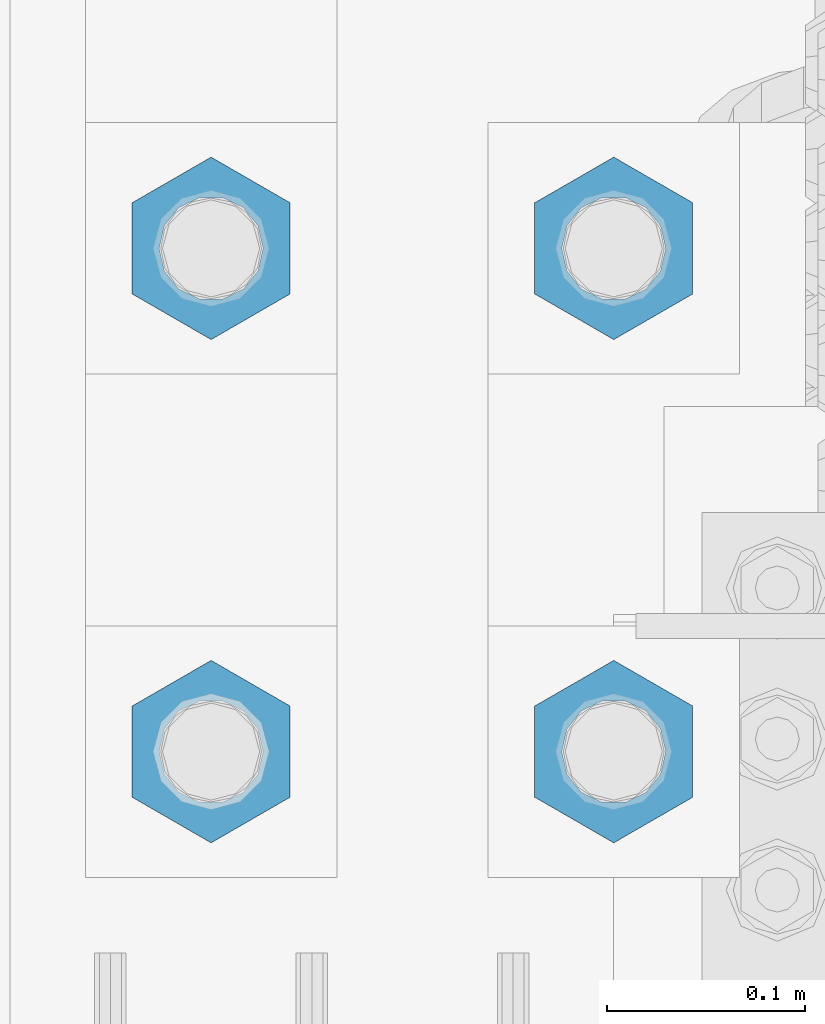
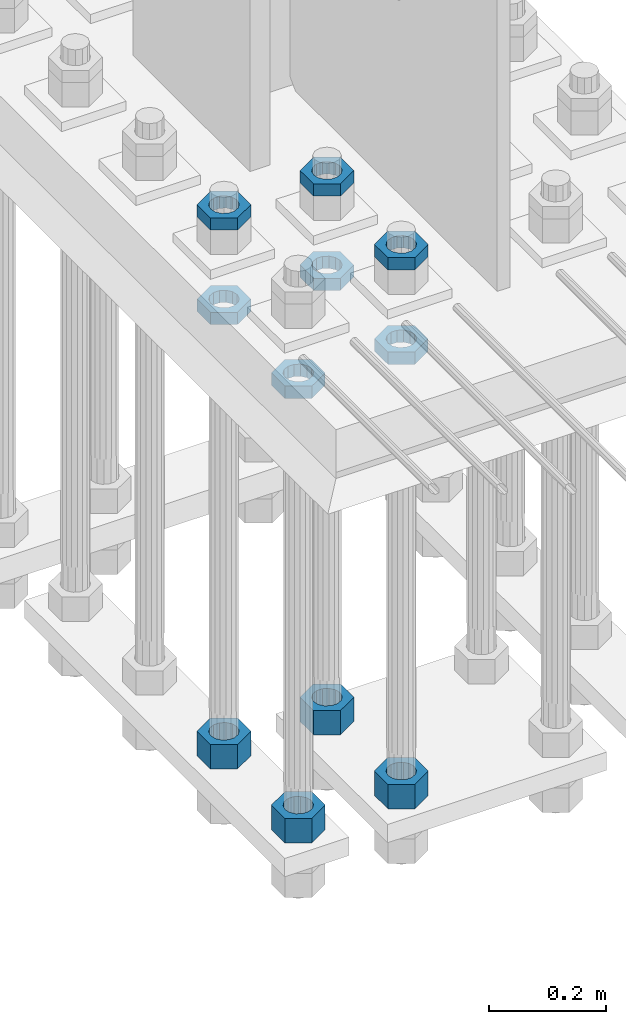
# One storey, part 2210 of 3843: 11 beams, 1 element without a shape of its own.
"""IFC2X3 building model written with IfcOpenShell, lengths in millimetres."""

import ifcopenshell
import ifcopenshell.guid

model = None  # the IFC model being written
_history = None  # IfcOwnerHistory: only IFC2X3 demands one
_inside = {}  # id of a spatial element -> (the spatial element, [elements in it])
_under = {}  # id of a project, library or spatial element -> (it, [spatial elements below it])
_declared = {}  # id of a project -> (the project, [libraries it declares])
_typed = {}  # id of a type object -> (the type object, [elements of that type])
_made_of = {}  # id of a material, layer set ... -> (it, [elements and type objects made of it])


def new_model(schema):
    """Start an empty IFC model of exactly this schema.

    Asked for "IFC4X3", IfcOpenShell would pick the latest addendum, in which some entities
    have other attributes; the version numbers below select the first issue.
    IFC2X3 requires an IfcOwnerHistory on every rooted entity: one is made here for all.
    """
    global model, _history
    if schema == "IFC4X3":
        model = ifcopenshell.file(schema_version=(4, 3, 0, 0))
    else:
        model = ifcopenshell.file(schema=schema)
    _inside.clear()
    _under.clear()
    _declared.clear()
    _typed.clear()
    _made_of.clear()
    _history = None
    if model.schema == "IFC2X3":
        org = make("IfcOrganization", Name="unknown")
        user = make(
            "IfcPersonAndOrganization",
            ThePerson=make("IfcPerson", FamilyName="unknown"),
            TheOrganization=org,
        )
        app = make(
            "IfcApplication",
            ApplicationDeveloper=org,
            Version="unknown",
            ApplicationFullName="unknown",
            ApplicationIdentifier="unknown",
        )
        _history = make(
            "IfcOwnerHistory",
            OwningUser=user,
            OwningApplication=app,
            ChangeAction="ADDED",
            CreationDate=0,
        )
    return model


def make(cls, **values):
    """One entity of the class cls with the attributes given. An attribute that is None is left unset."""
    return model.create_entity(
        cls, **{name: value for name, value in values.items() if value is not None}
    )


def rooted(cls, **values):
    """An entity with a GlobalId (a new one), such as an element, a storey or a relation."""
    return make(cls, GlobalId=ifcopenshell.guid.new(), OwnerHistory=_history, **values)


def si_unit(unit_type, name, prefix=None):
    """IfcSIUnit, for example si_unit("LENGTHUNIT", "METRE", prefix="MILLI")."""
    return make("IfcSIUnit", UnitType=unit_type, Prefix=prefix, Name=name)


def assignment(units):
    """IfcUnitAssignment: the units of a project."""
    return None if units is None else make("IfcUnitAssignment", Units=units)


def point(xyz):
    """IfcCartesianPoint."""
    return None if xyz is None else make("IfcCartesianPoint", Coordinates=xyz)


def direction(xyz):
    """IfcDirection."""
    return None if xyz is None else make("IfcDirection", DirectionRatios=xyz)


def frame(location, z_axis=None, x_axis=None):
    """IfcAxis2Placement3D, a coordinate frame: its origin and axes. An axis left out is left unset."""
    return make(
        "IfcAxis2Placement3D",
        Location=point(location),
        Axis=direction(z_axis),
        RefDirection=direction(x_axis),
    )


def origin_with_axes():
    """The frame at (0, 0, 0) with the z axis (0, 0, 1) and the x axis (1, 0, 0) written out."""
    return frame((0.0, 0.0, 0.0), z_axis=(0.0, 0.0, 1.0), x_axis=(1.0, 0.0, 0.0))


def place(relative_to, where):
    """IfcLocalPlacement: puts the frame where relative to a parent placement (None: the world)."""
    return make(
        "IfcLocalPlacement", PlacementRelTo=relative_to, RelativePlacement=where
    )


def context(
    kind, dimensions, precision=None, world=None, true_north=None, identifier=None
):
    """IfcGeometricRepresentationContext, for example the 3D "Model" context."""
    return make(
        "IfcGeometricRepresentationContext",
        ContextIdentifier=identifier,
        ContextType=kind,
        CoordinateSpaceDimension=dimensions,
        Precision=precision,
        WorldCoordinateSystem=world,
        TrueNorth=true_north,
    )


def subcontext(parent, identifier, kind, view, scale=None):
    """IfcGeometricRepresentationSubContext, for example "Body" below "Model"."""
    return make(
        "IfcGeometricRepresentationSubContext",
        ContextIdentifier=identifier,
        ContextType=kind,
        ParentContext=parent,
        TargetScale=scale,
        TargetView=view,
    )


def project(units=None, contexts=None):
    """IfcProject with its units and contexts."""
    return rooted(
        "IfcProject",
        Name="project",
        RepresentationContexts=contexts,
        UnitsInContext=assignment(units),
    )


def spatial(cls, under=None, at=None, **own):
    """A site, building, storey or space (cls), placed at a placement, below another one or the project."""
    s = rooted(cls, ObjectPlacement=at, **own)
    if under is not None:
        _under.setdefault(under.id(), (under, []))[1].append(s)
    return s


def faces_of(points, faces, orient=None, outer=None):
    """IfcFace entities. A face is a list of loops; a loop is a list of indices into points, from 0.

    orient and outer hold one flag for each loop. By default every Orientation is true, the
    first loop of a face is its IfcFaceOuterBound and the others are IfcFaceBound.
    """
    made = []
    for i, loops in enumerate(faces):
        bounds = []
        for j, loop in enumerate(loops):
            is_outer = j == 0 if outer is None else outer[i][j]
            bounds.append(
                make(
                    "IfcFaceOuterBound" if is_outer else "IfcFaceBound",
                    Bound=make("IfcPolyLoop", Polygon=[points[k] for k in loop]),
                    Orientation=True if orient is None else orient[i][j],
                )
            )
        made.append(make("IfcFace", Bounds=bounds))
    return made


def faceted_brep(points, faces, orient=None, outer=None, voids=None):
    """IfcFacetedBrep: a solid bounded by flat faces; with voids (closed shells), ...WithVoids."""
    shared = [point(p) for p in points]
    hull = make("IfcClosedShell", CfsFaces=faces_of(shared, faces, orient, outer))
    if voids is None:
        return make("IfcFacetedBrep", Outer=hull)
    return make(
        "IfcFacetedBrepWithVoids",
        Outer=hull,
        Voids=[
            make(cls, CfsFaces=faces_of(shared, fs, o, b)) for cls, fs, o, b in voids
        ],
    )


def shape(context_of_items, identifier, shape_type, items):
    """IfcShapeRepresentation: the items that make up one representation, for example the "Body"."""
    return make(
        "IfcShapeRepresentation",
        ContextOfItems=context_of_items,
        RepresentationIdentifier=identifier,
        RepresentationType=shape_type,
        Items=items,
    )


def material(Name=None, Category=None):
    """IfcMaterial."""
    return make("IfcMaterial", Name=Name, Category=Category)


def made_of(thing, what):
    """Note that an element or type object is made of a material, layer set ...; save() writes the relation."""
    if what is not None:
        _made_of.setdefault(what.id(), (what, []))[1].append(thing)
    return thing


def type_object(cls, material=None, **own):
    """A type object (cls), such as IfcWallType, which elements share."""
    return made_of(rooted(cls, **own), material)


def element(
    cls,
    number,
    at=None,
    inside=None,
    cuts=None,
    type_object=None,
    material=None,
    context=None,
    identifier="Body",
    shape_type=None,
    held_by="IfcProductDefinitionShape",
    body=None,
    shapes=None,
    **own,
):
    """One element of the class cls, such as IfcWall. Its Tag is "e" and its number.

    at: its placement. inside: the storey or other place that contains it. cuts: it is an
    opening in that element (IfcRelVoidsElement). A single representation is given by context,
    identifier, shape_type and body (its items); several are given by shapes. held_by: the class
    of the entity that holds the representations. save() writes the other relations.
    """
    e = rooted(cls, Tag="e%d" % number, ObjectPlacement=at, **own)
    if body is not None:
        shapes = [shape(context, identifier, shape_type, body)]
    if shapes is not None:
        e.Representation = make(held_by, Representations=shapes)
    if inside is not None:
        _inside.setdefault(inside.id(), (inside, []))[1].append(e)
    if cuts is not None:
        rooted(
            "IfcRelVoidsElement", RelatingBuildingElement=cuts, RelatedOpeningElement=e
        )
    if type_object is not None:
        _typed.setdefault(type_object.id(), (type_object, []))[1].append(e)
    return made_of(e, material)


def aggregate(whole, parts):
    """IfcRelAggregates: a whole, such as a stair, and the parts it consists of."""
    return rooted("IfcRelAggregates", RelatingObject=whole, RelatedObjects=parts)


def save(model, path):
    """Write the relations noted so far, then the file.

    IfcRelAggregates (storeys below a building ...), IfcRelContainedInSpatialStructure (elements
    in a storey), IfcRelDefinesByType, IfcRelAssociatesMaterial and IfcRelDeclares: one each for
    every whole, place, type object, material and project.
    """
    for whole, parts in _under.values():
        aggregate(whole, parts)
    for where, things in _inside.values():
        rooted(
            "IfcRelContainedInSpatialStructure",
            RelatedElements=things,
            RelatingStructure=where,
        )
    for kind, things in _typed.values():
        rooted("IfcRelDefinesByType", RelatedObjects=things, RelatingType=kind)
    for what, things in _made_of.values():
        rooted("IfcRelAssociatesMaterial", RelatedObjects=things, RelatingMaterial=what)
    for by, libraries in _declared.values():
        rooted("IfcRelDeclares", RelatingContext=by, RelatedDefinitions=libraries)
    model.write(path)


model = new_model("IFC2X3")

# Units and contexts
model_context = context("Model", 3, precision=1e-05, world=origin_with_axes())
body_context = subcontext(model_context, "Body", "Model", "MODEL_VIEW")
ifc_project = project(units=[si_unit("LENGTHUNIT", "METRE", prefix="MILLI"), si_unit("AREAUNIT", "SQUARE_METRE"), si_unit("VOLUMEUNIT", "CUBIC_METRE"), si_unit("MASSUNIT", "GRAM", prefix="KILO"), si_unit("TIMEUNIT", "SECOND"), si_unit("PLANEANGLEUNIT", "RADIAN"), si_unit("SOLIDANGLEUNIT", "STERADIAN"), si_unit("THERMODYNAMICTEMPERATUREUNIT", "DEGREE_CELSIUS"), si_unit("LUMINOUSINTENSITYUNIT", "LUMEN")], contexts=[model_context])

# Site, building, storey
site_placement = place(None, origin_with_axes())
site = spatial("IfcSite", under=ifc_project, at=site_placement, CompositionType="ELEMENT")
building_placement = place(site_placement, origin_with_axes())
building = spatial("IfcBuilding", under=site, at=building_placement, Name="Undefined", CompositionType="ELEMENT")
storey_placement = place(building_placement, origin_with_axes())
storey = spatial("IfcBuildingStorey", under=building, at=storey_placement, Name="Undefined", CompositionType="ELEMENT", Elevation=0.0)

# Assembly, beams
assembly_placement = place(storey_placement, origin_with_axes())
assembly = element("IfcElementAssembly", 1, at=assembly_placement, inside=storey, Name="TEMPLATE", AssemblyPlace="NOTDEFINED", PredefinedType="RIGID_FRAME")
ifc_material = material(Name="STEEL/A572-50")
beam_type_1 = type_object("IfcBeamType", Name="2_HALF_NUT", PredefinedType="NOTDEFINED")
beam_1_placement = place(assembly_placement, frame((36220.4, 58280.3, 30060.9), z_axis=(-1.0, 0.0, 0.0), x_axis=(0.0, 0.0, -1.0)))
beam_1 = element("IfcBeam", 2, at=beam_1_placement, type_object=beam_type_1, material=ifc_material, Name="NUT", ObjectType="2_HALF_NUT", context=body_context, shape_type="Brep", body=[
    faceted_brep([(0.0, -46.0369987487793, 0.0), (0.0, -23.0184993743896, -39.869213104248), (25.4000000000015, -23.0184993743896, -39.869213104248), (25.4000000000015, -46.0369987487793, 0.0), (0.0, 23.0184993743896, -39.869213104248), (25.4000000000015, 23.0184993743896, -39.869213104248), (0.0, 46.0369987487793, 0.0), (25.4000000000015, 46.0369987487793, 0.0), (0.0, 23.0184993743896, 39.869213104248), (25.4000000000015, 23.0184993743896, 39.869213104248), (0.0, -23.0184993743896, 39.869213104248), (25.4000000000015, -23.0184993743896, 39.869213104248), (0.0, 0.0, 26.1940002441406), (0.0, 11.3650617044477, 23.5999013092805), (25.4000000000015, 11.3650617044477, 23.5999013092805), (25.4000000000015, 0.0, 26.1940002441406), (0.0, 20.4791109456419, 16.3316083006721), (25.4000000000015, 20.4791109456419, 16.3316083006721), (0.0, 25.5370200498292, 5.82867859874386), (25.4000000000015, 25.5370200498292, 5.82867859874386), (0.0, 25.5370200498292, -5.82867859874386), (25.4000000000015, 25.5370200498292, -5.82867859874386), (0.0, 20.4791109456419, -16.3316083006721), (25.4000000000015, 20.4791109456419, -16.3316083006721), (0.0, 11.3650617044477, -23.5999013092805), (25.4000000000015, 11.3650617044477, -23.5999013092805), (0.0, 0.0, -26.1940002441406), (25.4000000000015, 0.0, -26.1940002441406), (0.0, -11.3650617044477, -23.5999013092805), (25.4000000000015, -11.3650617044477, -23.5999013092805), (0.0, -20.4791109456419, -16.3316083006721), (25.4000000000015, -20.4791109456419, -16.3316083006721), (0.0, -25.5370200498292, -5.82867859874386), (25.4000000000015, -25.5370200498292, -5.82867859874386), (0.0, -25.5370200498292, 5.82867859874386), (25.4000000000015, -25.5370200498292, 5.82867859874386), (0.0, -20.4791109456419, 16.3316083006721), (25.4000000000015, -20.4791109456419, 16.3316083006721), (0.0, -11.3650617044477, 23.5999013092805), (25.4000000000015, -11.3650617044477, 23.5999013092805)], [[[0, 1, 2, 3]], [[1, 4, 5, 2]], [[4, 6, 7, 5]], [[6, 8, 9, 7]], [[8, 10, 11, 9]], [[10, 0, 3, 11]], [[12, 13, 14, 15]], [[13, 16, 17, 14]], [[16, 18, 19, 17]], [[18, 20, 21, 19]], [[20, 22, 23, 21]], [[22, 24, 25, 23]], [[24, 26, 27, 25]], [[26, 28, 29, 27]], [[28, 30, 31, 29]], [[30, 32, 33, 31]], [[32, 34, 35, 33]], [[34, 36, 37, 35]], [[36, 38, 39, 37]], [[38, 12, 15, 39]], [[5, 7, 9, 11, 3, 2], [17, 19, 21, 23, 25, 27, 29, 31, 33, 35, 37, 39, 15, 14]], [[10, 8, 6, 4, 1, 0], [38, 36, 34, 32, 30, 28, 26, 24, 22, 20, 18, 16, 13, 12]]]),
])
beam_2_placement = place(assembly_placement, frame((36423.6, 58280.3, 30060.9), z_axis=(-1.0, 0.0, 0.0), x_axis=(0.0, 0.0, -1.0)))
beam_2 = element("IfcBeam", 3, at=beam_2_placement, type_object=beam_type_1, material=ifc_material, Name="NUT", ObjectType="2_HALF_NUT", context=body_context, shape_type="Brep", body=[
    faceted_brep([(0.0, -46.0369987487793, 0.0), (0.0, -23.0184993743896, -39.869213104248), (25.4000000000015, -23.0184993743896, -39.869213104248), (25.4000000000015, -46.0369987487793, 0.0), (0.0, 23.0184993743896, -39.869213104248), (25.4000000000015, 23.0184993743896, -39.869213104248), (0.0, 46.0369987487793, 0.0), (25.4000000000015, 46.0369987487793, 0.0), (0.0, 23.0184993743896, 39.869213104248), (25.4000000000015, 23.0184993743896, 39.869213104248), (0.0, -23.0184993743896, 39.869213104248), (25.4000000000015, -23.0184993743896, 39.869213104248), (0.0, 0.0, 26.1940002441406), (0.0, 11.3650617044477, 23.5999013092805), (25.4000000000015, 11.3650617044477, 23.5999013092805), (25.4000000000015, 0.0, 26.1940002441406), (0.0, 20.4791109456419, 16.3316083006721), (25.4000000000015, 20.4791109456419, 16.3316083006721), (0.0, 25.5370200498292, 5.82867859874386), (25.4000000000015, 25.5370200498292, 5.82867859874386), (0.0, 25.5370200498292, -5.82867859874386), (25.4000000000015, 25.5370200498292, -5.82867859874386), (0.0, 20.4791109456419, -16.3316083006721), (25.4000000000015, 20.4791109456419, -16.3316083006721), (0.0, 11.3650617044477, -23.5999013092805), (25.4000000000015, 11.3650617044477, -23.5999013092805), (0.0, 0.0, -26.1940002441406), (25.4000000000015, 0.0, -26.1940002441406), (0.0, -11.3650617044477, -23.5999013092805), (25.4000000000015, -11.3650617044477, -23.5999013092805), (0.0, -20.4791109456419, -16.3316083006721), (25.4000000000015, -20.4791109456419, -16.3316083006721), (0.0, -25.5370200498292, -5.82867859874386), (25.4000000000015, -25.5370200498292, -5.82867859874386), (0.0, -25.5370200498292, 5.82867859874386), (25.4000000000015, -25.5370200498292, 5.82867859874386), (0.0, -20.4791109456419, 16.3316083006721), (25.4000000000015, -20.4791109456419, 16.3316083006721), (0.0, -11.3650617044477, 23.5999013092805), (25.4000000000015, -11.3650617044477, 23.5999013092805)], [[[0, 1, 2, 3]], [[1, 4, 5, 2]], [[4, 6, 7, 5]], [[6, 8, 9, 7]], [[8, 10, 11, 9]], [[10, 0, 3, 11]], [[12, 13, 14, 15]], [[13, 16, 17, 14]], [[16, 18, 19, 17]], [[18, 20, 21, 19]], [[20, 22, 23, 21]], [[22, 24, 25, 23]], [[24, 26, 27, 25]], [[26, 28, 29, 27]], [[28, 30, 31, 29]], [[30, 32, 33, 31]], [[32, 34, 35, 33]], [[34, 36, 37, 35]], [[36, 38, 39, 37]], [[38, 12, 15, 39]], [[5, 7, 9, 11, 3, 2], [17, 19, 21, 23, 25, 27, 29, 31, 33, 35, 37, 39, 15, 14]], [[10, 8, 6, 4, 1, 0], [38, 36, 34, 32, 30, 28, 26, 24, 22, 20, 18, 16, 13, 12]]]),
])
beam_3_placement = place(assembly_placement, frame((36423.6, 58534.3, 30060.9), z_axis=(-1.0, 0.0, 0.0), x_axis=(0.0, 0.0, -1.0)))
beam_3 = element("IfcBeam", 4, at=beam_3_placement, type_object=beam_type_1, material=ifc_material, Name="NUT", ObjectType="2_HALF_NUT", context=body_context, shape_type="Brep", body=[
    faceted_brep([(0.0, -46.0369987487793, 0.0), (0.0, -23.0184993743896, -39.869213104248), (25.4000000000015, -23.0184993743896, -39.869213104248), (25.4000000000015, -46.0369987487793, 0.0), (0.0, 23.0184993743896, -39.869213104248), (25.4000000000015, 23.0184993743896, -39.869213104248), (0.0, 46.0369987487793, 0.0), (25.4000000000015, 46.0369987487793, 0.0), (0.0, 23.0184993743896, 39.869213104248), (25.4000000000015, 23.0184993743896, 39.869213104248), (0.0, -23.0184993743896, 39.869213104248), (25.4000000000015, -23.0184993743896, 39.869213104248), (0.0, 0.0, 26.1940002441406), (0.0, 11.3650617044477, 23.5999013092805), (25.4000000000015, 11.3650617044477, 23.5999013092805), (25.4000000000015, 0.0, 26.1940002441406), (0.0, 20.4791109456419, 16.3316083006721), (25.4000000000015, 20.4791109456419, 16.3316083006721), (0.0, 25.5370200498292, 5.82867859874386), (25.4000000000015, 25.5370200498292, 5.82867859874386), (0.0, 25.5370200498292, -5.82867859874386), (25.4000000000015, 25.5370200498292, -5.82867859874386), (0.0, 20.4791109456419, -16.3316083006721), (25.4000000000015, 20.4791109456419, -16.3316083006721), (0.0, 11.3650617044477, -23.5999013092805), (25.4000000000015, 11.3650617044477, -23.5999013092805), (0.0, 0.0, -26.1940002441406), (25.4000000000015, 0.0, -26.1940002441406), (0.0, -11.3650617044477, -23.5999013092805), (25.4000000000015, -11.3650617044477, -23.5999013092805), (0.0, -20.4791109456419, -16.3316083006721), (25.4000000000015, -20.4791109456419, -16.3316083006721), (0.0, -25.5370200498292, -5.82867859874386), (25.4000000000015, -25.5370200498292, -5.82867859874386), (0.0, -25.5370200498292, 5.82867859874386), (25.4000000000015, -25.5370200498292, 5.82867859874386), (0.0, -20.4791109456419, 16.3316083006721), (25.4000000000015, -20.4791109456419, 16.3316083006721), (0.0, -11.3650617044477, 23.5999013092805), (25.4000000000015, -11.3650617044477, 23.5999013092805)], [[[0, 1, 2, 3]], [[1, 4, 5, 2]], [[4, 6, 7, 5]], [[6, 8, 9, 7]], [[8, 10, 11, 9]], [[10, 0, 3, 11]], [[12, 13, 14, 15]], [[13, 16, 17, 14]], [[16, 18, 19, 17]], [[18, 20, 21, 19]], [[20, 22, 23, 21]], [[22, 24, 25, 23]], [[24, 26, 27, 25]], [[26, 28, 29, 27]], [[28, 30, 31, 29]], [[30, 32, 33, 31]], [[32, 34, 35, 33]], [[34, 36, 37, 35]], [[36, 38, 39, 37]], [[38, 12, 15, 39]], [[5, 7, 9, 11, 3, 2], [17, 19, 21, 23, 25, 27, 29, 31, 33, 35, 37, 39, 15, 14]], [[10, 8, 6, 4, 1, 0], [38, 36, 34, 32, 30, 28, 26, 24, 22, 20, 18, 16, 13, 12]]]),
])
beam_4_placement = place(assembly_placement, frame((36220.4, 58534.3, 30060.9), z_axis=(-1.0, 0.0, 0.0), x_axis=(0.0, 0.0, -1.0)))
beam_4 = element("IfcBeam", 5, at=beam_4_placement, type_object=beam_type_1, material=ifc_material, Name="NUT", ObjectType="2_HALF_NUT", context=body_context, shape_type="Brep", body=[
    faceted_brep([(0.0, -46.0369987487793, 0.0), (0.0, -23.0184993743896, -39.869213104248), (25.4000000000015, -23.0184993743896, -39.869213104248), (25.4000000000015, -46.0369987487793, 0.0), (0.0, 23.0184993743896, -39.869213104248), (25.4000000000015, 23.0184993743896, -39.869213104248), (0.0, 46.0369987487793, 0.0), (25.4000000000015, 46.0369987487793, 0.0), (0.0, 23.0184993743896, 39.869213104248), (25.4000000000015, 23.0184993743896, 39.869213104248), (0.0, -23.0184993743896, 39.869213104248), (25.4000000000015, -23.0184993743896, 39.869213104248), (0.0, 0.0, 26.1940002441406), (0.0, 11.3650617044477, 23.5999013092805), (25.4000000000015, 11.3650617044477, 23.5999013092805), (25.4000000000015, 0.0, 26.1940002441406), (0.0, 20.4791109456419, 16.3316083006721), (25.4000000000015, 20.4791109456419, 16.3316083006721), (0.0, 25.5370200498292, 5.82867859874386), (25.4000000000015, 25.5370200498292, 5.82867859874386), (0.0, 25.5370200498292, -5.82867859874386), (25.4000000000015, 25.5370200498292, -5.82867859874386), (0.0, 20.4791109456419, -16.3316083006721), (25.4000000000015, 20.4791109456419, -16.3316083006721), (0.0, 11.3650617044477, -23.5999013092805), (25.4000000000015, 11.3650617044477, -23.5999013092805), (0.0, 0.0, -26.1940002441406), (25.4000000000015, 0.0, -26.1940002441406), (0.0, -11.3650617044477, -23.5999013092805), (25.4000000000015, -11.3650617044477, -23.5999013092805), (0.0, -20.4791109456419, -16.3316083006721), (25.4000000000015, -20.4791109456419, -16.3316083006721), (0.0, -25.5370200498292, -5.82867859874386), (25.4000000000015, -25.5370200498292, -5.82867859874386), (0.0, -25.5370200498292, 5.82867859874386), (25.4000000000015, -25.5370200498292, 5.82867859874386), (0.0, -20.4791109456419, 16.3316083006721), (25.4000000000015, -20.4791109456419, 16.3316083006721), (0.0, -11.3650617044477, 23.5999013092805), (25.4000000000015, -11.3650617044477, 23.5999013092805)], [[[0, 1, 2, 3]], [[1, 4, 5, 2]], [[4, 6, 7, 5]], [[6, 8, 9, 7]], [[8, 10, 11, 9]], [[10, 0, 3, 11]], [[12, 13, 14, 15]], [[13, 16, 17, 14]], [[16, 18, 19, 17]], [[18, 20, 21, 19]], [[20, 22, 23, 21]], [[22, 24, 25, 23]], [[24, 26, 27, 25]], [[26, 28, 29, 27]], [[28, 30, 31, 29]], [[30, 32, 33, 31]], [[32, 34, 35, 33]], [[34, 36, 37, 35]], [[36, 38, 39, 37]], [[38, 12, 15, 39]], [[5, 7, 9, 11, 3, 2], [17, 19, 21, 23, 25, 27, 29, 31, 33, 35, 37, 39, 15, 14]], [[10, 8, 6, 4, 1, 0], [38, 36, 34, 32, 30, 28, 26, 24, 22, 20, 18, 16, 13, 12]]]),
])
beam_5_placement = place(assembly_placement, frame((36423.6, 58280.3, 30257.75), z_axis=(-1.0, 0.0, 0.0), x_axis=(0.0, 0.0, -1.0)))
beam_5 = element("IfcBeam", 6, at=beam_5_placement, type_object=beam_type_1, material=ifc_material, Name="NUT", ObjectType="2_HALF_NUT", context=body_context, shape_type="Brep", body=[
    faceted_brep([(0.0, -46.0369987487793, 0.0), (0.0, -23.0184993743896, -39.869213104248), (25.4000000000015, -23.0184993743896, -39.869213104248), (25.4000000000015, -46.0369987487793, 0.0), (0.0, 23.0184993743896, -39.869213104248), (25.4000000000015, 23.0184993743896, -39.869213104248), (0.0, 46.0369987487793, 0.0), (25.4000000000015, 46.0369987487793, 0.0), (0.0, 23.0184993743896, 39.869213104248), (25.4000000000015, 23.0184993743896, 39.869213104248), (0.0, -23.0184993743896, 39.869213104248), (25.4000000000015, -23.0184993743896, 39.869213104248), (0.0, 0.0, 26.1940002441406), (0.0, 11.3650617044477, 23.5999013092805), (25.4000000000015, 11.3650617044477, 23.5999013092805), (25.4000000000015, 0.0, 26.1940002441406), (0.0, 20.4791109456419, 16.3316083006721), (25.4000000000015, 20.4791109456419, 16.3316083006721), (0.0, 25.5370200498292, 5.82867859874386), (25.4000000000015, 25.5370200498292, 5.82867859874386), (0.0, 25.5370200498292, -5.82867859874386), (25.4000000000015, 25.5370200498292, -5.82867859874386), (0.0, 20.4791109456419, -16.3316083006721), (25.4000000000015, 20.4791109456419, -16.3316083006721), (0.0, 11.3650617044477, -23.5999013092805), (25.4000000000015, 11.3650617044477, -23.5999013092805), (0.0, 0.0, -26.1940002441406), (25.4000000000015, 0.0, -26.1940002441406), (0.0, -11.3650617044477, -23.5999013092805), (25.4000000000015, -11.3650617044477, -23.5999013092805), (0.0, -20.4791109456419, -16.3316083006721), (25.4000000000015, -20.4791109456419, -16.3316083006721), (0.0, -25.5370200498292, -5.82867859874386), (25.4000000000015, -25.5370200498292, -5.82867859874386), (0.0, -25.5370200498292, 5.82867859874386), (25.4000000000015, -25.5370200498292, 5.82867859874386), (0.0, -20.4791109456419, 16.3316083006721), (25.4000000000015, -20.4791109456419, 16.3316083006721), (0.0, -11.3650617044477, 23.5999013092805), (25.4000000000015, -11.3650617044477, 23.5999013092805)], [[[0, 1, 2, 3]], [[1, 4, 5, 2]], [[4, 6, 7, 5]], [[6, 8, 9, 7]], [[8, 10, 11, 9]], [[10, 0, 3, 11]], [[12, 13, 14, 15]], [[13, 16, 17, 14]], [[16, 18, 19, 17]], [[18, 20, 21, 19]], [[20, 22, 23, 21]], [[22, 24, 25, 23]], [[24, 26, 27, 25]], [[26, 28, 29, 27]], [[28, 30, 31, 29]], [[30, 32, 33, 31]], [[32, 34, 35, 33]], [[34, 36, 37, 35]], [[36, 38, 39, 37]], [[38, 12, 15, 39]], [[5, 7, 9, 11, 3, 2], [17, 19, 21, 23, 25, 27, 29, 31, 33, 35, 37, 39, 15, 14]], [[10, 8, 6, 4, 1, 0], [38, 36, 34, 32, 30, 28, 26, 24, 22, 20, 18, 16, 13, 12]]]),
])
beam_6_placement = place(assembly_placement, frame((36423.6, 58534.3, 30257.75), z_axis=(-1.0, 0.0, 0.0), x_axis=(0.0, 0.0, -1.0)))
beam_6 = element("IfcBeam", 7, at=beam_6_placement, type_object=beam_type_1, material=ifc_material, Name="NUT", ObjectType="2_HALF_NUT", context=body_context, shape_type="Brep", body=[
    faceted_brep([(0.0, -46.0369987487793, 0.0), (0.0, -23.0184993743896, -39.869213104248), (25.4000000000015, -23.0184993743896, -39.869213104248), (25.4000000000015, -46.0369987487793, 0.0), (0.0, 23.0184993743896, -39.869213104248), (25.4000000000015, 23.0184993743896, -39.869213104248), (0.0, 46.0369987487793, 0.0), (25.4000000000015, 46.0369987487793, 0.0), (0.0, 23.0184993743896, 39.869213104248), (25.4000000000015, 23.0184993743896, 39.869213104248), (0.0, -23.0184993743896, 39.869213104248), (25.4000000000015, -23.0184993743896, 39.869213104248), (0.0, 0.0, 26.1940002441406), (0.0, 11.3650617044477, 23.5999013092805), (25.4000000000015, 11.3650617044477, 23.5999013092805), (25.4000000000015, 0.0, 26.1940002441406), (0.0, 20.4791109456419, 16.3316083006721), (25.4000000000015, 20.4791109456419, 16.3316083006721), (0.0, 25.5370200498292, 5.82867859874386), (25.4000000000015, 25.5370200498292, 5.82867859874386), (0.0, 25.5370200498292, -5.82867859874386), (25.4000000000015, 25.5370200498292, -5.82867859874386), (0.0, 20.4791109456419, -16.3316083006721), (25.4000000000015, 20.4791109456419, -16.3316083006721), (0.0, 11.3650617044477, -23.5999013092805), (25.4000000000015, 11.3650617044477, -23.5999013092805), (0.0, 0.0, -26.1940002441406), (25.4000000000015, 0.0, -26.1940002441406), (0.0, -11.3650617044477, -23.5999013092805), (25.4000000000015, -11.3650617044477, -23.5999013092805), (0.0, -20.4791109456419, -16.3316083006721), (25.4000000000015, -20.4791109456419, -16.3316083006721), (0.0, -25.5370200498292, -5.82867859874386), (25.4000000000015, -25.5370200498292, -5.82867859874386), (0.0, -25.5370200498292, 5.82867859874386), (25.4000000000015, -25.5370200498292, 5.82867859874386), (0.0, -20.4791109456419, 16.3316083006721), (25.4000000000015, -20.4791109456419, 16.3316083006721), (0.0, -11.3650617044477, 23.5999013092805), (25.4000000000015, -11.3650617044477, 23.5999013092805)], [[[0, 1, 2, 3]], [[1, 4, 5, 2]], [[4, 6, 7, 5]], [[6, 8, 9, 7]], [[8, 10, 11, 9]], [[10, 0, 3, 11]], [[12, 13, 14, 15]], [[13, 16, 17, 14]], [[16, 18, 19, 17]], [[18, 20, 21, 19]], [[20, 22, 23, 21]], [[22, 24, 25, 23]], [[24, 26, 27, 25]], [[26, 28, 29, 27]], [[28, 30, 31, 29]], [[30, 32, 33, 31]], [[32, 34, 35, 33]], [[34, 36, 37, 35]], [[36, 38, 39, 37]], [[38, 12, 15, 39]], [[5, 7, 9, 11, 3, 2], [17, 19, 21, 23, 25, 27, 29, 31, 33, 35, 37, 39, 15, 14]], [[10, 8, 6, 4, 1, 0], [38, 36, 34, 32, 30, 28, 26, 24, 22, 20, 18, 16, 13, 12]]]),
])
beam_7_placement = place(assembly_placement, frame((36220.4, 58534.3, 30257.75), z_axis=(-1.0, 0.0, 0.0), x_axis=(0.0, 0.0, -1.0)))
beam_7 = element("IfcBeam", 8, at=beam_7_placement, type_object=beam_type_1, material=ifc_material, Name="NUT", ObjectType="2_HALF_NUT", context=body_context, shape_type="Brep", body=[
    faceted_brep([(0.0, -46.0369987487793, 0.0), (0.0, -23.0184993743896, -39.869213104248), (25.4000000000015, -23.0184993743896, -39.869213104248), (25.4000000000015, -46.0369987487793, 0.0), (0.0, 23.0184993743896, -39.869213104248), (25.4000000000015, 23.0184993743896, -39.869213104248), (0.0, 46.0369987487793, 0.0), (25.4000000000015, 46.0369987487793, 0.0), (0.0, 23.0184993743896, 39.869213104248), (25.4000000000015, 23.0184993743896, 39.869213104248), (0.0, -23.0184993743896, 39.869213104248), (25.4000000000015, -23.0184993743896, 39.869213104248), (0.0, 0.0, 26.1940002441406), (0.0, 11.3650617044477, 23.5999013092805), (25.4000000000015, 11.3650617044477, 23.5999013092805), (25.4000000000015, 0.0, 26.1940002441406), (0.0, 20.4791109456419, 16.3316083006721), (25.4000000000015, 20.4791109456419, 16.3316083006721), (0.0, 25.5370200498292, 5.82867859874386), (25.4000000000015, 25.5370200498292, 5.82867859874386), (0.0, 25.5370200498292, -5.82867859874386), (25.4000000000015, 25.5370200498292, -5.82867859874386), (0.0, 20.4791109456419, -16.3316083006721), (25.4000000000015, 20.4791109456419, -16.3316083006721), (0.0, 11.3650617044477, -23.5999013092805), (25.4000000000015, 11.3650617044477, -23.5999013092805), (0.0, 0.0, -26.1940002441406), (25.4000000000015, 0.0, -26.1940002441406), (0.0, -11.3650617044477, -23.5999013092805), (25.4000000000015, -11.3650617044477, -23.5999013092805), (0.0, -20.4791109456419, -16.3316083006721), (25.4000000000015, -20.4791109456419, -16.3316083006721), (0.0, -25.5370200498292, -5.82867859874386), (25.4000000000015, -25.5370200498292, -5.82867859874386), (0.0, -25.5370200498292, 5.82867859874386), (25.4000000000015, -25.5370200498292, 5.82867859874386), (0.0, -20.4791109456419, 16.3316083006721), (25.4000000000015, -20.4791109456419, 16.3316083006721), (0.0, -11.3650617044477, 23.5999013092805), (25.4000000000015, -11.3650617044477, 23.5999013092805)], [[[0, 1, 2, 3]], [[1, 4, 5, 2]], [[4, 6, 7, 5]], [[6, 8, 9, 7]], [[8, 10, 11, 9]], [[10, 0, 3, 11]], [[12, 13, 14, 15]], [[13, 16, 17, 14]], [[16, 18, 19, 17]], [[18, 20, 21, 19]], [[20, 22, 23, 21]], [[22, 24, 25, 23]], [[24, 26, 27, 25]], [[26, 28, 29, 27]], [[28, 30, 31, 29]], [[30, 32, 33, 31]], [[32, 34, 35, 33]], [[34, 36, 37, 35]], [[36, 38, 39, 37]], [[38, 12, 15, 39]], [[5, 7, 9, 11, 3, 2], [17, 19, 21, 23, 25, 27, 29, 31, 33, 35, 37, 39, 15, 14]], [[10, 8, 6, 4, 1, 0], [38, 36, 34, 32, 30, 28, 26, 24, 22, 20, 18, 16, 13, 12]]]),
])
beam_type_2 = type_object("IfcBeamType", Name="2_HEAVY_HEX_NUT", PredefinedType="NOTDEFINED")
beam_8_placement = place(assembly_placement, frame((36423.6, 58280.3, 29159.2), z_axis=(-1.0, 0.0, 0.0), x_axis=(0.0, 0.0, -1.0)))
beam_8 = element("IfcBeam", 9, at=beam_8_placement, type_object=beam_type_2, material=ifc_material, Name="NUT", ObjectType="2_HEAVY_HEX_NUT", context=body_context, shape_type="Brep", body=[
    faceted_brep([(0.0, -46.0369987487793, 0.0), (0.0, -23.0184993743896, -39.869213104248), (50.7999999999993, -23.0184993743896, -39.869213104248), (50.7999999999993, -46.0369987487793, 0.0), (0.0, 23.0184993743896, -39.869213104248), (50.7999999999993, 23.0184993743896, -39.869213104248), (0.0, 46.0369987487793, 0.0), (50.7999999999993, 46.0369987487793, 0.0), (0.0, 23.0184993743896, 39.869213104248), (50.7999999999993, 23.0184993743896, 39.869213104248), (0.0, -23.0184993743896, 39.869213104248), (50.7999999999993, -23.0184993743896, 39.869213104248), (0.0, 0.0, 26.1940002441406), (0.0, 11.3650617044477, 23.5999013092805), (50.7999999999993, 11.3650617044477, 23.5999013092805), (50.7999999999993, 0.0, 26.1940002441406), (0.0, 20.4791109456419, 16.3316083006721), (50.7999999999993, 20.4791109456419, 16.3316083006721), (0.0, 25.5370200498292, 5.82867859874386), (50.7999999999993, 25.5370200498292, 5.82867859874386), (0.0, 25.5370200498292, -5.82867859874386), (50.7999999999993, 25.5370200498292, -5.82867859874386), (0.0, 20.4791109456419, -16.3316083006721), (50.7999999999993, 20.4791109456419, -16.3316083006721), (0.0, 11.3650617044477, -23.5999013092805), (50.7999999999993, 11.3650617044477, -23.5999013092805), (0.0, 0.0, -26.1940002441406), (50.7999999999993, 0.0, -26.1940002441406), (0.0, -11.3650617044477, -23.5999013092805), (50.7999999999993, -11.3650617044477, -23.5999013092805), (0.0, -20.4791109456419, -16.3316083006721), (50.7999999999993, -20.4791109456419, -16.3316083006721), (0.0, -25.5370200498292, -5.82867859874386), (50.7999999999993, -25.5370200498292, -5.82867859874386), (0.0, -25.5370200498292, 5.82867859874386), (50.7999999999993, -25.5370200498292, 5.82867859874386), (0.0, -20.4791109456419, 16.3316083006721), (50.7999999999993, -20.4791109456419, 16.3316083006721), (0.0, -11.3650617044477, 23.5999013092805), (50.7999999999993, -11.3650617044477, 23.5999013092805)], [[[0, 1, 2, 3]], [[1, 4, 5, 2]], [[4, 6, 7, 5]], [[6, 8, 9, 7]], [[8, 10, 11, 9]], [[10, 0, 3, 11]], [[12, 13, 14, 15]], [[13, 16, 17, 14]], [[16, 18, 19, 17]], [[18, 20, 21, 19]], [[20, 22, 23, 21]], [[22, 24, 25, 23]], [[24, 26, 27, 25]], [[26, 28, 29, 27]], [[28, 30, 31, 29]], [[30, 32, 33, 31]], [[32, 34, 35, 33]], [[34, 36, 37, 35]], [[36, 38, 39, 37]], [[38, 12, 15, 39]], [[5, 7, 9, 11, 3, 2], [17, 19, 21, 23, 25, 27, 29, 31, 33, 35, 37, 39, 15, 14]], [[10, 8, 6, 4, 1, 0], [38, 36, 34, 32, 30, 28, 26, 24, 22, 20, 18, 16, 13, 12]]]),
])
beam_9_placement = place(assembly_placement, frame((36423.6, 58534.3, 29159.2), z_axis=(-1.0, 0.0, 0.0), x_axis=(0.0, 0.0, -1.0)))
beam_9 = element("IfcBeam", 10, at=beam_9_placement, type_object=beam_type_2, material=ifc_material, Name="NUT", ObjectType="2_HEAVY_HEX_NUT", context=body_context, shape_type="Brep", body=[
    faceted_brep([(0.0, -46.0369987487793, 0.0), (0.0, -23.0184993743896, -39.869213104248), (50.7999999999993, -23.0184993743896, -39.869213104248), (50.7999999999993, -46.0369987487793, 0.0), (0.0, 23.0184993743896, -39.869213104248), (50.7999999999993, 23.0184993743896, -39.869213104248), (0.0, 46.0369987487793, 0.0), (50.7999999999993, 46.0369987487793, 0.0), (0.0, 23.0184993743896, 39.869213104248), (50.7999999999993, 23.0184993743896, 39.869213104248), (0.0, -23.0184993743896, 39.869213104248), (50.7999999999993, -23.0184993743896, 39.869213104248), (0.0, 0.0, 26.1940002441406), (0.0, 11.3650617044477, 23.5999013092805), (50.7999999999993, 11.3650617044477, 23.5999013092805), (50.7999999999993, 0.0, 26.1940002441406), (0.0, 20.4791109456419, 16.3316083006721), (50.7999999999993, 20.4791109456419, 16.3316083006721), (0.0, 25.5370200498292, 5.82867859874386), (50.7999999999993, 25.5370200498292, 5.82867859874386), (0.0, 25.5370200498292, -5.82867859874386), (50.7999999999993, 25.5370200498292, -5.82867859874386), (0.0, 20.4791109456419, -16.3316083006721), (50.7999999999993, 20.4791109456419, -16.3316083006721), (0.0, 11.3650617044477, -23.5999013092805), (50.7999999999993, 11.3650617044477, -23.5999013092805), (0.0, 0.0, -26.1940002441406), (50.7999999999993, 0.0, -26.1940002441406), (0.0, -11.3650617044477, -23.5999013092805), (50.7999999999993, -11.3650617044477, -23.5999013092805), (0.0, -20.4791109456419, -16.3316083006721), (50.7999999999993, -20.4791109456419, -16.3316083006721), (0.0, -25.5370200498292, -5.82867859874386), (50.7999999999993, -25.5370200498292, -5.82867859874386), (0.0, -25.5370200498292, 5.82867859874386), (50.7999999999993, -25.5370200498292, 5.82867859874386), (0.0, -20.4791109456419, 16.3316083006721), (50.7999999999993, -20.4791109456419, 16.3316083006721), (0.0, -11.3650617044477, 23.5999013092805), (50.7999999999993, -11.3650617044477, 23.5999013092805)], [[[0, 1, 2, 3]], [[1, 4, 5, 2]], [[4, 6, 7, 5]], [[6, 8, 9, 7]], [[8, 10, 11, 9]], [[10, 0, 3, 11]], [[12, 13, 14, 15]], [[13, 16, 17, 14]], [[16, 18, 19, 17]], [[18, 20, 21, 19]], [[20, 22, 23, 21]], [[22, 24, 25, 23]], [[24, 26, 27, 25]], [[26, 28, 29, 27]], [[28, 30, 31, 29]], [[30, 32, 33, 31]], [[32, 34, 35, 33]], [[34, 36, 37, 35]], [[36, 38, 39, 37]], [[38, 12, 15, 39]], [[5, 7, 9, 11, 3, 2], [17, 19, 21, 23, 25, 27, 29, 31, 33, 35, 37, 39, 15, 14]], [[10, 8, 6, 4, 1, 0], [38, 36, 34, 32, 30, 28, 26, 24, 22, 20, 18, 16, 13, 12]]]),
])
beam_10_placement = place(assembly_placement, frame((36220.4, 58534.3, 29159.2), z_axis=(-1.0, 0.0, 0.0), x_axis=(0.0, 0.0, -1.0)))
beam_10 = element("IfcBeam", 11, at=beam_10_placement, type_object=beam_type_2, material=ifc_material, Name="NUT", ObjectType="2_HEAVY_HEX_NUT", context=body_context, shape_type="Brep", body=[
    faceted_brep([(0.0, -46.0369987487793, 0.0), (0.0, -23.0184993743896, -39.869213104248), (50.7999999999993, -23.0184993743896, -39.869213104248), (50.7999999999993, -46.0369987487793, 0.0), (0.0, 23.0184993743896, -39.869213104248), (50.7999999999993, 23.0184993743896, -39.869213104248), (0.0, 46.0369987487793, 0.0), (50.7999999999993, 46.0369987487793, 0.0), (0.0, 23.0184993743896, 39.869213104248), (50.7999999999993, 23.0184993743896, 39.869213104248), (0.0, -23.0184993743896, 39.869213104248), (50.7999999999993, -23.0184993743896, 39.869213104248), (0.0, 0.0, 26.1940002441406), (0.0, 11.3650617044477, 23.5999013092805), (50.7999999999993, 11.3650617044477, 23.5999013092805), (50.7999999999993, 0.0, 26.1940002441406), (0.0, 20.4791109456419, 16.3316083006721), (50.7999999999993, 20.4791109456419, 16.3316083006721), (0.0, 25.5370200498292, 5.82867859874386), (50.7999999999993, 25.5370200498292, 5.82867859874386), (0.0, 25.5370200498292, -5.82867859874386), (50.7999999999993, 25.5370200498292, -5.82867859874386), (0.0, 20.4791109456419, -16.3316083006721), (50.7999999999993, 20.4791109456419, -16.3316083006721), (0.0, 11.3650617044477, -23.5999013092805), (50.7999999999993, 11.3650617044477, -23.5999013092805), (0.0, 0.0, -26.1940002441406), (50.7999999999993, 0.0, -26.1940002441406), (0.0, -11.3650617044477, -23.5999013092805), (50.7999999999993, -11.3650617044477, -23.5999013092805), (0.0, -20.4791109456419, -16.3316083006721), (50.7999999999993, -20.4791109456419, -16.3316083006721), (0.0, -25.5370200498292, -5.82867859874386), (50.7999999999993, -25.5370200498292, -5.82867859874386), (0.0, -25.5370200498292, 5.82867859874386), (50.7999999999993, -25.5370200498292, 5.82867859874386), (0.0, -20.4791109456419, 16.3316083006721), (50.7999999999993, -20.4791109456419, 16.3316083006721), (0.0, -11.3650617044477, 23.5999013092805), (50.7999999999993, -11.3650617044477, 23.5999013092805)], [[[0, 1, 2, 3]], [[1, 4, 5, 2]], [[4, 6, 7, 5]], [[6, 8, 9, 7]], [[8, 10, 11, 9]], [[10, 0, 3, 11]], [[12, 13, 14, 15]], [[13, 16, 17, 14]], [[16, 18, 19, 17]], [[18, 20, 21, 19]], [[20, 22, 23, 21]], [[22, 24, 25, 23]], [[24, 26, 27, 25]], [[26, 28, 29, 27]], [[28, 30, 31, 29]], [[30, 32, 33, 31]], [[32, 34, 35, 33]], [[34, 36, 37, 35]], [[36, 38, 39, 37]], [[38, 12, 15, 39]], [[5, 7, 9, 11, 3, 2], [17, 19, 21, 23, 25, 27, 29, 31, 33, 35, 37, 39, 15, 14]], [[10, 8, 6, 4, 1, 0], [38, 36, 34, 32, 30, 28, 26, 24, 22, 20, 18, 16, 13, 12]]]),
])
beam_11_placement = place(assembly_placement, frame((36220.4, 58280.3, 29159.2), z_axis=(-1.0, 0.0, 0.0), x_axis=(0.0, 0.0, -1.0)))
beam_11 = element("IfcBeam", 12, at=beam_11_placement, type_object=beam_type_2, material=ifc_material, Name="NUT", ObjectType="2_HEAVY_HEX_NUT", context=body_context, shape_type="Brep", body=[
    faceted_brep([(0.0, -46.0369987487793, 0.0), (0.0, -23.0184993743896, -39.869213104248), (50.7999999999993, -23.0184993743896, -39.869213104248), (50.7999999999993, -46.0369987487793, 0.0), (0.0, 23.0184993743896, -39.869213104248), (50.7999999999993, 23.0184993743896, -39.869213104248), (0.0, 46.0369987487793, 0.0), (50.7999999999993, 46.0369987487793, 0.0), (0.0, 23.0184993743896, 39.869213104248), (50.7999999999993, 23.0184993743896, 39.869213104248), (0.0, -23.0184993743896, 39.869213104248), (50.7999999999993, -23.0184993743896, 39.869213104248), (0.0, 0.0, 26.1940002441406), (0.0, 11.3650617044477, 23.5999013092805), (50.7999999999993, 11.3650617044477, 23.5999013092805), (50.7999999999993, 0.0, 26.1940002441406), (0.0, 20.4791109456419, 16.3316083006721), (50.7999999999993, 20.4791109456419, 16.3316083006721), (0.0, 25.5370200498292, 5.82867859874386), (50.7999999999993, 25.5370200498292, 5.82867859874386), (0.0, 25.5370200498292, -5.82867859874386), (50.7999999999993, 25.5370200498292, -5.82867859874386), (0.0, 20.4791109456419, -16.3316083006721), (50.7999999999993, 20.4791109456419, -16.3316083006721), (0.0, 11.3650617044477, -23.5999013092805), (50.7999999999993, 11.3650617044477, -23.5999013092805), (0.0, 0.0, -26.1940002441406), (50.7999999999993, 0.0, -26.1940002441406), (0.0, -11.3650617044477, -23.5999013092805), (50.7999999999993, -11.3650617044477, -23.5999013092805), (0.0, -20.4791109456419, -16.3316083006721), (50.7999999999993, -20.4791109456419, -16.3316083006721), (0.0, -25.5370200498292, -5.82867859874386), (50.7999999999993, -25.5370200498292, -5.82867859874386), (0.0, -25.5370200498292, 5.82867859874386), (50.7999999999993, -25.5370200498292, 5.82867859874386), (0.0, -20.4791109456419, 16.3316083006721), (50.7999999999993, -20.4791109456419, 16.3316083006721), (0.0, -11.3650617044477, 23.5999013092805), (50.7999999999993, -11.3650617044477, 23.5999013092805)], [[[0, 1, 2, 3]], [[1, 4, 5, 2]], [[4, 6, 7, 5]], [[6, 8, 9, 7]], [[8, 10, 11, 9]], [[10, 0, 3, 11]], [[12, 13, 14, 15]], [[13, 16, 17, 14]], [[16, 18, 19, 17]], [[18, 20, 21, 19]], [[20, 22, 23, 21]], [[22, 24, 25, 23]], [[24, 26, 27, 25]], [[26, 28, 29, 27]], [[28, 30, 31, 29]], [[30, 32, 33, 31]], [[32, 34, 35, 33]], [[34, 36, 37, 35]], [[36, 38, 39, 37]], [[38, 12, 15, 39]], [[5, 7, 9, 11, 3, 2], [17, 19, 21, 23, 25, 27, 29, 31, 33, 35, 37, 39, 15, 14]], [[10, 8, 6, 4, 1, 0], [38, 36, 34, 32, 30, 28, 26, 24, 22, 20, 18, 16, 13, 12]]]),
])
aggregate(assembly, [beam_8, beam_9, beam_10, beam_11, beam_1, beam_2, beam_3, beam_4, beam_5, beam_6, beam_7])

save(model, "model.ifc")
